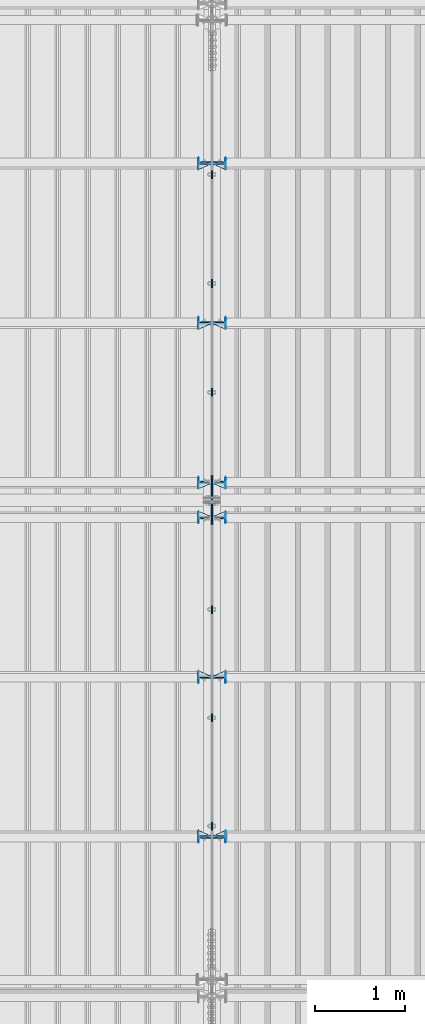
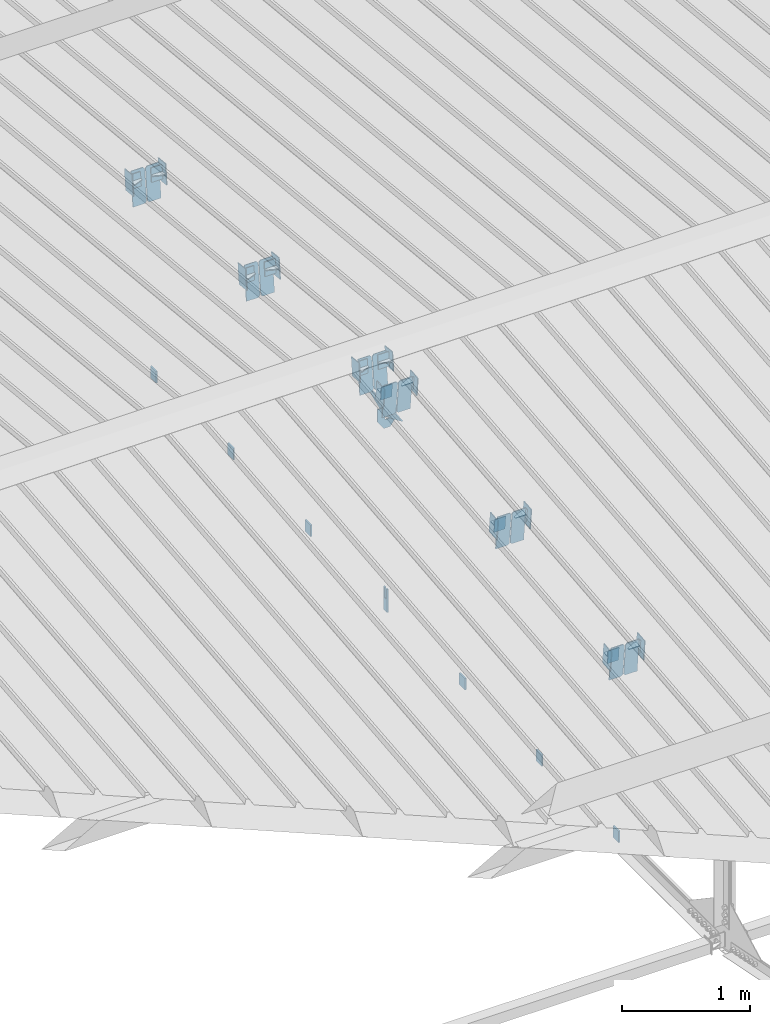
# One storey, part 129 of 709: 58 plates, 21 elements without a shape of their own.
"""IFC4 building model written with IfcOpenShell, lengths in millimetres."""

from ifc_helpers import new_model, si_unit, direction, frame, origin_with_axes, place, context, subcontext, project, spatial, line, indexed_curve, outline, extrude, material, element, aggregate, save


model = new_model("IFC4")

# Units and contexts
model_context = context("Model", 3, precision=0.2, world=origin_with_axes(), true_north=direction((0.0, 1.0)))
body_context = subcontext(model_context, "Body", "Model", "MODEL_VIEW")
ifc_project = project(units=[si_unit("LENGTHUNIT", "METRE", prefix="MILLI"), si_unit("AREAUNIT", "SQUARE_METRE"), si_unit("VOLUMEUNIT", "CUBIC_METRE"), si_unit("MASSUNIT", "GRAM", prefix="KILO"), si_unit("TIMEUNIT", "SECOND"), si_unit("PLANEANGLEUNIT", "RADIAN"), si_unit("SOLIDANGLEUNIT", "STERADIAN"), si_unit("THERMODYNAMICTEMPERATUREUNIT", "DEGREE_CELSIUS"), si_unit("LUMINOUSINTENSITYUNIT", "LUMEN")], contexts=[model_context])

# Site, building, storey
site_placement = place(None, origin_with_axes())
site = spatial("IfcSite", under=ifc_project, at=site_placement, CompositionType="ELEMENT")
building_placement = place(site_placement, origin_with_axes())
building = spatial("IfcBuilding", under=site, at=building_placement, Name="Undefined", CompositionType="ELEMENT")
storey_placement = place(building_placement, origin_with_axes())
storey = spatial("IfcBuildingStorey", under=building, at=storey_placement, Name="Undefined", CompositionType="ELEMENT", Elevation=0.0)

# Assembly, plates
assembly_1_placement = place(storey_placement, frame((28000.0, 346.0, 7089.70002), z_axis=(1.0, 0.0, 0.0), x_axis=(0.0, 0.9950371902, 0.099503719)))
assembly_1 = element("IfcElementAssembly", 1, at=assembly_1_placement, inside=storey)
ifc_material = material(Name="C355-6", Category="STEEL")
plate_1_placement = place(assembly_1_placement, frame((10515.43997, 163.0, 127.0), z_axis=(-1.0, 0.0, 0.0), x_axis=(0.0, 0.0, -1.0)))
plate_1 = element("IfcPlate", 2, at=plate_1_placement, material=ifc_material, ObjectType="589", context=body_context, shape_type="SolidModel", body=[
    extrude(outline(indexed_curve([(0.0, 0.0), (108.0, 0.0), (123.0, 15.0), (123.0, 311.0), (108.0, 326.0), (0.0, 326.0)], segments=[line(1, 2, 3, 4, 5, 6, 1)])), frame((0.0, 0.0, 4.0), z_axis=(0.0, 0.0, 1.0), x_axis=(1.0, 0.0, 0.0)), (0.0, 0.0, -1.0), 8.0),
])
plate_2_placement = place(assembly_1_placement, frame((8733.29528, 163.0, 127.0), z_axis=(-1.0, 0.0, 0.0), x_axis=(0.0, 0.0, -1.0)))
plate_2 = element("IfcPlate", 3, at=plate_2_placement, material=ifc_material, ObjectType="585", context=body_context, shape_type="SolidModel", body=[
    extrude(outline(indexed_curve([(0.0, 0.0), (108.0, 0.0), (123.0, 15.0), (123.0, 311.0), (108.0, 326.0), (0.0, 326.0)], segments=[line(1, 2, 3, 4, 5, 6, 1)])), frame((0.0, 0.0, 4.0), z_axis=(0.0, 0.0, 1.0), x_axis=(1.0, 0.0, 0.0)), (0.0, 0.0, -1.0), 8.0),
])
plate_3_placement = place(assembly_1_placement, frame((8733.29528, 163.0, -127.0), z_axis=(1.0, 0.0, 0.0), x_axis=(0.0, 0.0, 1.0)))
plate_3 = element("IfcPlate", 4, at=plate_3_placement, material=ifc_material, ObjectType="585", context=body_context, shape_type="SolidModel", body=[
    extrude(outline(indexed_curve([(0.0, 0.0), (108.0, 0.0), (123.0, 15.0), (123.0, 311.0), (108.0, 326.0), (0.0, 326.0)], segments=[line(1, 2, 3, 4, 5, 6, 1)])), frame((0.0, 0.0, 4.0), z_axis=(0.0, 0.0, 1.0), x_axis=(1.0, 0.0, 0.0)), (0.0, 0.0, -1.0), 8.0),
])
plate_4_placement = place(assembly_1_placement, frame((6951.15059, 163.0, 127.0), z_axis=(-1.0, 0.0, 0.0), x_axis=(0.0, 0.0, -1.0)))
plate_4 = element("IfcPlate", 5, at=plate_4_placement, material=ifc_material, ObjectType="585", context=body_context, shape_type="SolidModel", body=[
    extrude(outline(indexed_curve([(0.0, 0.0), (108.0, 0.0), (123.0, 15.0), (123.0, 311.0), (108.0, 326.0), (0.0, 326.0)], segments=[line(1, 2, 3, 4, 5, 6, 1)])), frame((0.0, 0.0, 4.0), z_axis=(0.0, 0.0, 1.0), x_axis=(1.0, 0.0, 0.0)), (0.0, 0.0, -1.0), 8.0),
])
plate_5_placement = place(assembly_1_placement, frame((6951.15059, 163.0, -127.0), z_axis=(1.0, 0.0, 0.0), x_axis=(0.0, 0.0, 1.0)))
plate_5 = element("IfcPlate", 6, at=plate_5_placement, material=ifc_material, ObjectType="585", context=body_context, shape_type="SolidModel", body=[
    extrude(outline(indexed_curve([(0.0, 0.0), (108.0, 0.0), (123.0, 15.0), (123.0, 311.0), (108.0, 326.0), (0.0, 326.0)], segments=[line(1, 2, 3, 4, 5, 6, 1)])), frame((0.0, 0.0, 4.0), z_axis=(0.0, 0.0, 1.0), x_axis=(1.0, 0.0, 0.0)), (0.0, 0.0, -1.0), 8.0),
])
plate_6_placement = place(assembly_1_placement, frame((10515.43997, 163.0, -127.0), z_axis=(1.0, 0.0, 0.0), x_axis=(0.0, 0.0, 1.0)))
plate_6 = element("IfcPlate", 7, at=plate_6_placement, material=ifc_material, ObjectType="589", context=body_context, shape_type="SolidModel", body=[
    extrude(outline(indexed_curve([(0.0, 0.0), (108.0, 0.0), (123.0, 15.0), (123.0, 311.0), (108.0, 326.0), (0.0, 326.0)], segments=[line(1, 2, 3, 4, 5, 6, 1)])), frame((0.0, 0.0, 4.0), z_axis=(0.0, 0.0, 1.0), x_axis=(1.0, 0.0, 0.0)), (0.0, 0.0, -1.0), 8.0),
])
plate_7_placement = place(assembly_1_placement, frame((10651.77731, -302.35483, 0.0), z_axis=(0.0, 0.0, 1.0), x_axis=(0.099503719, 0.9950371902, 0.0)))
plate_7 = element("IfcPlate", 8, at=plate_7_placement, material=ifc_material, ObjectType="439", context=body_context, shape_type="SolidModel", body=[
    extrude(outline(indexed_curve([(0.0, 0.0), (130.0, 0.0), (105.12407, 248.7593)], segments=[line(1, 2, 3, 1)])), frame((0.0, 0.0, 6.0), z_axis=(0.0, 0.0, 1.0), x_axis=(1.0, 0.0, 0.0)), (0.0, 0.0, -1.0), 12.0),
])
aggregate(assembly_1, [plate_1, plate_2, plate_3, plate_4, plate_5, plate_6, plate_7])

assembly_2_placement = place(storey_placement, frame((28000.0, 21654.0, 7089.70002), z_axis=(-1.0, 0.0, 0.0), x_axis=(0.0, -0.9950371902, 0.099503719)))
assembly_2 = element("IfcElementAssembly", 9, at=assembly_2_placement, inside=storey)
plate_8_placement = place(assembly_2_placement, frame((6951.15059, 163.0, -127.0), z_axis=(1.0, 0.0, 0.0), x_axis=(0.0, 0.0, 1.0)))
plate_8 = element("IfcPlate", 10, at=plate_8_placement, material=ifc_material, ObjectType="585", context=body_context, shape_type="SolidModel", body=[
    extrude(outline(indexed_curve([(0.0, 0.0), (108.0, 0.0), (123.0, 15.0), (123.0, 311.0), (108.0, 326.0), (0.0, 326.0)], segments=[line(1, 2, 3, 4, 5, 6, 1)])), frame((0.0, 0.0, 4.0), z_axis=(0.0, 0.0, 1.0), x_axis=(1.0, 0.0, 0.0)), (0.0, 0.0, -1.0), 8.0),
])
plate_9_placement = place(assembly_2_placement, frame((8733.29528, 163.0, -127.0), z_axis=(1.0, 0.0, 0.0), x_axis=(0.0, 0.0, 1.0)))
plate_9 = element("IfcPlate", 11, at=plate_9_placement, material=ifc_material, ObjectType="585", context=body_context, shape_type="SolidModel", body=[
    extrude(outline(indexed_curve([(0.0, 0.0), (108.0, 0.0), (123.0, 15.0), (123.0, 311.0), (108.0, 326.0), (0.0, 326.0)], segments=[line(1, 2, 3, 4, 5, 6, 1)])), frame((0.0, 0.0, 4.0), z_axis=(0.0, 0.0, 1.0), x_axis=(1.0, 0.0, 0.0)), (0.0, 0.0, -1.0), 8.0),
])
plate_10_placement = place(assembly_2_placement, frame((8733.29528, 163.0, 127.0), z_axis=(-1.0, 0.0, 0.0), x_axis=(0.0, 0.0, -1.0)))
plate_10 = element("IfcPlate", 12, at=plate_10_placement, material=ifc_material, ObjectType="585", context=body_context, shape_type="SolidModel", body=[
    extrude(outline(indexed_curve([(0.0, 0.0), (108.0, 0.0), (123.0, 15.0), (123.0, 311.0), (108.0, 326.0), (0.0, 326.0)], segments=[line(1, 2, 3, 4, 5, 6, 1)])), frame((0.0, 0.0, 4.0), z_axis=(0.0, 0.0, 1.0), x_axis=(1.0, 0.0, 0.0)), (0.0, 0.0, -1.0), 8.0),
])
plate_11_placement = place(assembly_2_placement, frame((10515.43997, 163.0, -127.0), z_axis=(1.0, 0.0, 0.0), x_axis=(0.0, 0.0, 1.0)))
plate_11 = element("IfcPlate", 13, at=plate_11_placement, material=ifc_material, ObjectType="589", context=body_context, shape_type="SolidModel", body=[
    extrude(outline(indexed_curve([(0.0, 0.0), (108.0, 0.0), (123.0, 15.0), (123.0, 311.0), (108.0, 326.0), (0.0, 326.0)], segments=[line(1, 2, 3, 4, 5, 6, 1)])), frame((0.0, 0.0, 4.0), z_axis=(0.0, 0.0, 1.0), x_axis=(1.0, 0.0, 0.0)), (0.0, 0.0, -1.0), 8.0),
])
plate_12_placement = place(assembly_2_placement, frame((10515.43997, 163.0, 127.0), z_axis=(-1.0, 0.0, 0.0), x_axis=(0.0, 0.0, -1.0)))
plate_12 = element("IfcPlate", 14, at=plate_12_placement, material=ifc_material, ObjectType="589", context=body_context, shape_type="SolidModel", body=[
    extrude(outline(indexed_curve([(0.0, 0.0), (108.0, 0.0), (123.0, 15.0), (123.0, 311.0), (108.0, 326.0), (0.0, 326.0)], segments=[line(1, 2, 3, 4, 5, 6, 1)])), frame((0.0, 0.0, 4.0), z_axis=(0.0, 0.0, 1.0), x_axis=(1.0, 0.0, 0.0)), (0.0, 0.0, -1.0), 8.0),
])
plate_13_placement = place(assembly_2_placement, frame((6951.15059, 163.0, 127.0), z_axis=(-1.0, 0.0, 0.0), x_axis=(0.0, 0.0, -1.0)))
plate_13 = element("IfcPlate", 15, at=plate_13_placement, material=ifc_material, ObjectType="585", context=body_context, shape_type="SolidModel", body=[
    extrude(outline(indexed_curve([(0.0, 0.0), (108.0, 0.0), (123.0, 15.0), (123.0, 311.0), (108.0, 326.0), (0.0, 326.0)], segments=[line(1, 2, 3, 4, 5, 6, 1)])), frame((0.0, 0.0, 4.0), z_axis=(0.0, 0.0, 1.0), x_axis=(1.0, 0.0, 0.0)), (0.0, 0.0, -1.0), 8.0),
])
plate_14_placement = place(assembly_2_placement, frame((10651.77731, -302.35483, 0.0), z_axis=(0.0, 0.0, 1.0), x_axis=(0.099503719, 0.9950371902, 0.0)))
plate_14 = element("IfcPlate", 16, at=plate_14_placement, material=ifc_material, ObjectType="439", context=body_context, shape_type="SolidModel", body=[
    extrude(outline(indexed_curve([(0.0, 0.0), (130.0, 0.0), (105.12407, 248.7593)], segments=[line(1, 2, 3, 1)])), frame((0.0, 0.0, 6.0), z_axis=(0.0, 0.0, 1.0), x_axis=(1.0, 0.0, 0.0)), (0.0, 0.0, -1.0), 12.0),
])
aggregate(assembly_2, [plate_8, plate_9, plate_10, plate_11, plate_12, plate_13, plate_14])

assembly_3_placement = place(storey_placement, frame((28000.0, 10985.0, 8155.10002), z_axis=(0.0, -1.0, 0.0), x_axis=(0.0, 0.0, -1.0)))
assembly_3 = element("IfcElementAssembly", 17, at=assembly_3_placement, inside=storey)
plate_15_placement = place(assembly_3_placement, frame((206.36285, -87.0, 14.0), z_axis=(0.0, 0.0, -1.0), x_axis=(0.0, 1.0, 0.0)))
plate_15 = element("IfcPlate", 18, at=plate_15_placement, material=ifc_material, ObjectType="440", context=body_context, shape_type="SolidModel", body=[
    extrude(outline(indexed_curve([(0.0, 0.0), (71.0, 0.0), (71.0, 120.0), (103.0, 120.0), (103.0, 0.0), (174.0, 0.0), (174.0, 120.0), (117.0, 200.0), (57.0, 200.0), (0.0, 120.0)], segments=[line(1, 2, 3, 4, 5, 6, 7, 8, 9, 10, 1)])), frame((0.0, 0.0, 4.0), z_axis=(0.0, 0.0, 1.0), x_axis=(1.0, 0.0, 0.0)), (0.0, 0.0, -1.0), 8.0),
])
plate_16_placement = place(assembly_3_placement, frame((2165.1, 0.0, 30.0), z_axis=(0.0, 1.0, 0.0), x_axis=(0.0, 0.0, -1.0)))
plate_16 = element("IfcPlate", 19, at=plate_16_placement, material=ifc_material, ObjectType="441", context=body_context, shape_type="SolidModel", body=[
    extrude(outline(indexed_curve([(0.0, 0.0), (60.0, 0.0), (60.0, 220.0), (41.0, 220.0), (41.0, 120.0), (19.0, 120.0), (19.0, 220.0), (0.0, 220.0)], segments=[line(1, 2, 3, 4, 5, 6, 7, 8, 1)])), frame((0.0, 0.0, 6.0), z_axis=(0.0, 0.0, 1.0), x_axis=(1.0, 0.0, 0.0)), (0.0, 0.0, -1.0), 12.0),
])
aggregate(assembly_3, [plate_15, plate_16])

# Assembly, plate
assembly_4_placement = place(storey_placement, frame((28000.0, 7334.75, 6100.00002), z_axis=(-1.0, 0.0, 0.0), x_axis=(0.0, 1.0, 0.0)))
assembly_4 = element("IfcElementAssembly", 20, at=assembly_4_placement, inside=storey)
plate_17_placement = place(assembly_4_placement, origin_with_axes())
plate_17 = element("IfcPlate", 21, at=plate_17_placement, material=ifc_material, ObjectType="491", context=body_context, shape_type="SolidModel", body=[
    extrude(outline(indexed_curve([(0.0, 0.0), (90.0, 0.0), (90.0, 110.0), (0.0, 110.0)], segments=[line(1, 2, 3, 4, 1)])), frame((0.0, 0.0, 6.0), z_axis=(0.0, 0.0, 1.0), x_axis=(1.0, 0.0, 0.0)), (0.0, 0.0, -1.0), 12.0),
])
aggregate(assembly_4, [plate_17])

assembly_5_placement = place(storey_placement, frame((28000.0, 8536.5, 6100.00002), z_axis=(-1.0, 0.0, 0.0), x_axis=(0.0, 1.0, 0.0)))
assembly_5 = element("IfcElementAssembly", 22, at=assembly_5_placement, inside=storey)
plate_18_placement = place(assembly_5_placement, origin_with_axes())
plate_18 = element("IfcPlate", 23, at=plate_18_placement, material=ifc_material, ObjectType="491", context=body_context, shape_type="SolidModel", body=[
    extrude(outline(indexed_curve([(0.0, 0.0), (90.0, 0.0), (90.0, 110.0), (0.0, 110.0)], segments=[line(1, 2, 3, 4, 1)])), frame((0.0, 0.0, 6.0), z_axis=(0.0, 0.0, 1.0), x_axis=(1.0, 0.0, 0.0)), (0.0, 0.0, -1.0), 12.0),
])
aggregate(assembly_5, [plate_18])

assembly_6_placement = place(storey_placement, frame((28000.0, 9738.25, 6100.00002), z_axis=(-1.0, 0.0, 0.0), x_axis=(0.0, 1.0, 0.0)))
assembly_6 = element("IfcElementAssembly", 24, at=assembly_6_placement, inside=storey)
plate_19_placement = place(assembly_6_placement, origin_with_axes())
plate_19 = element("IfcPlate", 25, at=plate_19_placement, material=ifc_material, ObjectType="491", context=body_context, shape_type="SolidModel", body=[
    extrude(outline(indexed_curve([(0.0, 0.0), (90.0, 0.0), (90.0, 110.0), (0.0, 110.0)], segments=[line(1, 2, 3, 4, 1)])), frame((0.0, 0.0, 6.0), z_axis=(0.0, 0.0, 1.0), x_axis=(1.0, 0.0, 0.0)), (0.0, 0.0, -1.0), 12.0),
])
aggregate(assembly_6, [plate_19])

assembly_7_placement = place(storey_placement, frame((28000.0, 12149.25, 6100.00002), z_axis=(-1.0, 0.0, 0.0), x_axis=(0.0, 1.0, 0.0)))
assembly_7 = element("IfcElementAssembly", 26, at=assembly_7_placement, inside=storey)
plate_20_placement = place(assembly_7_placement, origin_with_axes())
plate_20 = element("IfcPlate", 27, at=plate_20_placement, material=ifc_material, ObjectType="491", context=body_context, shape_type="SolidModel", body=[
    extrude(outline(indexed_curve([(0.0, 0.0), (90.0, 0.0), (90.0, 110.0), (0.0, 110.0)], segments=[line(1, 2, 3, 4, 1)])), frame((0.0, 0.0, 6.0), z_axis=(0.0, 0.0, 1.0), x_axis=(1.0, 0.0, 0.0)), (0.0, 0.0, -1.0), 12.0),
])
aggregate(assembly_7, [plate_20])

assembly_8_placement = place(storey_placement, frame((28000.0, 13358.5, 6100.00002), z_axis=(-1.0, 0.0, 0.0), x_axis=(0.0, 1.0, 0.0)))
assembly_8 = element("IfcElementAssembly", 28, at=assembly_8_placement, inside=storey)
plate_21_placement = place(assembly_8_placement, origin_with_axes())
plate_21 = element("IfcPlate", 29, at=plate_21_placement, material=ifc_material, ObjectType="491", context=body_context, shape_type="SolidModel", body=[
    extrude(outline(indexed_curve([(0.0, 0.0), (90.0, 0.0), (90.0, 110.0), (0.0, 110.0)], segments=[line(1, 2, 3, 4, 1)])), frame((0.0, 0.0, 6.0), z_axis=(0.0, 0.0, 1.0), x_axis=(1.0, 0.0, 0.0)), (0.0, 0.0, -1.0), 12.0),
])
aggregate(assembly_8, [plate_21])

assembly_9_placement = place(storey_placement, frame((28000.0, 14567.75, 6100.00002), z_axis=(-1.0, 0.0, 0.0), x_axis=(0.0, 1.0, 0.0)))
assembly_9 = element("IfcElementAssembly", 30, at=assembly_9_placement, inside=storey)
plate_22_placement = place(assembly_9_placement, origin_with_axes())
plate_22 = element("IfcPlate", 31, at=plate_22_placement, material=ifc_material, ObjectType="491", context=body_context, shape_type="SolidModel", body=[
    extrude(outline(indexed_curve([(0.0, 0.0), (90.0, 0.0), (90.0, 110.0), (0.0, 110.0)], segments=[line(1, 2, 3, 4, 1)])), frame((0.0, 0.0, 6.0), z_axis=(0.0, 0.0, 1.0), x_axis=(1.0, 0.0, 0.0)), (0.0, 0.0, -1.0), 12.0),
])
aggregate(assembly_9, [plate_22])

# Assembly, plates
assembly_10_placement = place(storey_placement, frame((22000.0, 7263.34988, 7854.7991), z_axis=(0.0, 0.9950371902, 0.099503719), x_axis=(1.0, 0.0, 0.0)))
assembly_10 = element("IfcElementAssembly", 32, at=assembly_10_placement, inside=storey)
plate_23_placement = place(assembly_10_placement, frame((5953.0, 0.0, 60.0), z_axis=(0.0, -1.0, 0.0), x_axis=(-1.0, 0.0, 0.0)))
plate_23 = element("IfcPlate", 33, at=plate_23_placement, material=ifc_material, ObjectType="588", context=body_context, shape_type="SolidModel", body=[
    extrude(outline(indexed_curve([(0.0, 36.0), (80.0, 0.0), (100.0, 0.0), (100.0, 56.0), (0.0, 56.0)], segments=[line(1, 2, 3, 4, 5, 1)])), frame((0.0, 0.0, 4.0), z_axis=(0.0, 0.0, 1.0), x_axis=(1.0, 0.0, 0.0)), (0.0, 0.0, -1.0), 8.0),
])
plate_24_placement = place(assembly_10_placement, frame((5953.0, 65.0, 0.0), z_axis=(0.0, 0.0, 1.0), x_axis=(-1.0, 0.0, 0.0)))
plate_24 = element("IfcPlate", 34, at=plate_24_placement, material=ifc_material, ObjectType="587", context=body_context, shape_type="SolidModel", body=[
    extrude(outline(indexed_curve([(0.0, 0.0), (100.0, 0.0), (100.0, 130.0), (0.0, 130.0)], segments=[line(1, 2, 3, 4, 1)])), frame((0.0, 0.0, 4.0), z_axis=(0.0, 0.0, 1.0), x_axis=(1.0, 0.0, 0.0)), (0.0, 0.0, -1.0), 8.0),
])
plate_25_placement = place(assembly_10_placement, frame((5849.0, -98.0, 60.0), z_axis=(1.0, 0.0, 0.0), x_axis=(0.0, 0.0, -1.0)))
plate_25 = element("IfcPlate", 35, at=plate_25_placement, material=ifc_material, ObjectType="586", context=body_context, shape_type="SolidModel", body=[
    extrude(outline(indexed_curve([(0.0, 0.0), (120.0, 0.0), (120.0, 196.0), (0.0, 196.0)], segments=[line(1, 2, 3, 4, 1)])), frame((0.0, 0.0, 4.0), z_axis=(0.0, 0.0, 1.0), x_axis=(1.0, 0.0, 0.0)), (0.0, 0.0, -1.0), 8.0),
])
aggregate(assembly_10, [plate_23, plate_24, plate_25])

assembly_11_placement = place(storey_placement, frame((22000.0, 9036.65012, 8032.12913), z_axis=(0.0, 0.9950371902, 0.099503719), x_axis=(1.0, 0.0, 0.0)))
assembly_11 = element("IfcElementAssembly", 36, at=assembly_11_placement, inside=storey)
plate_26_placement = place(assembly_11_placement, frame((5849.0, -98.0, 60.0), z_axis=(1.0, 0.0, 0.0), x_axis=(0.0, 0.0, -1.0)))
plate_26 = element("IfcPlate", 37, at=plate_26_placement, material=ifc_material, ObjectType="586", context=body_context, shape_type="SolidModel", body=[
    extrude(outline(indexed_curve([(0.0, 0.0), (120.0, 0.0), (120.0, 196.0), (0.0, 196.0)], segments=[line(1, 2, 3, 4, 1)])), frame((0.0, 0.0, 4.0), z_axis=(0.0, 0.0, 1.0), x_axis=(1.0, 0.0, 0.0)), (0.0, 0.0, -1.0), 8.0),
])
plate_27_placement = place(assembly_11_placement, frame((5953.0, 0.0, 60.0), z_axis=(0.0, -1.0, 0.0), x_axis=(-1.0, 0.0, 0.0)))
plate_27 = element("IfcPlate", 38, at=plate_27_placement, material=ifc_material, ObjectType="588", context=body_context, shape_type="SolidModel", body=[
    extrude(outline(indexed_curve([(0.0, 36.0), (80.0, 0.0), (100.0, 0.0), (100.0, 56.0), (0.0, 56.0)], segments=[line(1, 2, 3, 4, 5, 1)])), frame((0.0, 0.0, 4.0), z_axis=(0.0, 0.0, 1.0), x_axis=(1.0, 0.0, 0.0)), (0.0, 0.0, -1.0), 8.0),
])
plate_28_placement = place(assembly_11_placement, frame((5953.0, 65.0, 0.0), z_axis=(0.0, 0.0, 1.0), x_axis=(-1.0, 0.0, 0.0)))
plate_28 = element("IfcPlate", 39, at=plate_28_placement, material=ifc_material, ObjectType="587", context=body_context, shape_type="SolidModel", body=[
    extrude(outline(indexed_curve([(0.0, 0.0), (100.0, 0.0), (100.0, 130.0), (0.0, 130.0)], segments=[line(1, 2, 3, 4, 1)])), frame((0.0, 0.0, 4.0), z_axis=(0.0, 0.0, 1.0), x_axis=(1.0, 0.0, 0.0)), (0.0, 0.0, -1.0), 8.0),
])
aggregate(assembly_11, [plate_26, plate_27, plate_28])

assembly_12_placement = place(storey_placement, frame((22000.0, 10808.95533, 8219.40952), z_axis=(0.0, 0.9950371902, 0.099503719), x_axis=(1.0, 0.0, 0.0)))
assembly_12 = element("IfcElementAssembly", 40, at=assembly_12_placement, inside=storey)
plate_29_placement = place(assembly_12_placement, frame((5953.0, 0.0, 60.0), z_axis=(0.0, -1.0, 0.0), x_axis=(-1.0, 0.0, 0.0)))
plate_29 = element("IfcPlate", 41, at=plate_29_placement, material=ifc_material, ObjectType="588", context=body_context, shape_type="SolidModel", body=[
    extrude(outline(indexed_curve([(0.0, 36.0), (80.0, 0.0), (100.0, 0.0), (100.0, 56.0), (0.0, 56.0)], segments=[line(1, 2, 3, 4, 5, 1)])), frame((0.0, 0.0, 4.0), z_axis=(0.0, 0.0, 1.0), x_axis=(1.0, 0.0, 0.0)), (0.0, 0.0, -1.0), 8.0),
])
plate_30_placement = place(assembly_12_placement, frame((5953.0, 65.0, 0.0), z_axis=(0.0, 0.0, 1.0), x_axis=(-1.0, 0.0, 0.0)))
plate_30 = element("IfcPlate", 42, at=plate_30_placement, material=ifc_material, ObjectType="587", context=body_context, shape_type="SolidModel", body=[
    extrude(outline(indexed_curve([(0.0, 0.0), (100.0, 0.0), (100.0, 130.0), (0.0, 130.0)], segments=[line(1, 2, 3, 4, 1)])), frame((0.0, 0.0, 4.0), z_axis=(0.0, 0.0, 1.0), x_axis=(1.0, 0.0, 0.0)), (0.0, 0.0, -1.0), 8.0),
])
plate_31_placement = place(assembly_12_placement, frame((5849.0, -88.0, 60.0), z_axis=(1.0, 0.0, 0.0), x_axis=(0.0, 0.0, -1.0)))
plate_31 = element("IfcPlate", 43, at=plate_31_placement, material=ifc_material, ObjectType="590", context=body_context, shape_type="SolidModel", body=[
    extrude(outline(indexed_curve([(0.0, 0.0), (120.0, 0.0), (120.0, 176.0), (0.0, 176.0)], segments=[line(1, 2, 3, 4, 1)])), frame((0.0, 0.0, 4.0), z_axis=(0.0, 0.0, 1.0), x_axis=(1.0, 0.0, 0.0)), (0.0, 0.0, -1.0), 8.0),
])
aggregate(assembly_12, [plate_29, plate_30, plate_31])

assembly_13_placement = place(storey_placement, frame((28000.0, 11191.04467, 8219.40952), z_axis=(0.0, -0.9950371902, 0.099503719), x_axis=(-1.0, 0.0, 0.0)))
assembly_13 = element("IfcElementAssembly", 44, at=assembly_13_placement, inside=storey)
plate_32_placement = place(assembly_13_placement, frame((151.0, -88.0, -60.0), z_axis=(-1.0, 0.0, 0.0), x_axis=(0.0, 0.0, 1.0)))
plate_32 = element("IfcPlate", 45, at=plate_32_placement, material=ifc_material, ObjectType="590", context=body_context, shape_type="SolidModel", body=[
    extrude(outline(indexed_curve([(0.0, 0.0), (120.0, 0.0), (120.0, 176.0), (0.0, 176.0)], segments=[line(1, 2, 3, 4, 1)])), frame((0.0, 0.0, 4.0), z_axis=(0.0, 0.0, 1.0), x_axis=(1.0, 0.0, 0.0)), (0.0, 0.0, -1.0), 8.0),
])
plate_33_placement = place(assembly_13_placement, frame((47.0, 0.0, 60.0), z_axis=(0.0, 1.0, 0.0), x_axis=(1.0, 0.0, 0.0)))
plate_33 = element("IfcPlate", 46, at=plate_33_placement, material=ifc_material, ObjectType="588", context=body_context, shape_type="SolidModel", body=[
    extrude(outline(indexed_curve([(0.0, 36.0), (80.0, 0.0), (100.0, 0.0), (100.0, 56.0), (0.0, 56.0)], segments=[line(1, 2, 3, 4, 5, 1)])), frame((0.0, 0.0, 4.0), z_axis=(0.0, 0.0, 1.0), x_axis=(1.0, 0.0, 0.0)), (0.0, 0.0, -1.0), 8.0),
])
plate_34_placement = place(assembly_13_placement, frame((47.0, -65.0, 0.0), z_axis=(0.0, 0.0, 1.0), x_axis=(1.0, 0.0, 0.0)))
plate_34 = element("IfcPlate", 47, at=plate_34_placement, material=ifc_material, ObjectType="587", context=body_context, shape_type="SolidModel", body=[
    extrude(outline(indexed_curve([(0.0, 0.0), (100.0, 0.0), (100.0, 130.0), (0.0, 130.0)], segments=[line(1, 2, 3, 4, 1)])), frame((0.0, 0.0, 4.0), z_axis=(0.0, 0.0, 1.0), x_axis=(1.0, 0.0, 0.0)), (0.0, 0.0, -1.0), 8.0),
])
aggregate(assembly_13, [plate_32, plate_33, plate_34])

assembly_14_placement = place(storey_placement, frame((28000.0, 12963.34988, 8032.12913), z_axis=(0.0, -0.9950371902, 0.099503719), x_axis=(-1.0, 0.0, 0.0)))
assembly_14 = element("IfcElementAssembly", 48, at=assembly_14_placement, inside=storey)
plate_35_placement = place(assembly_14_placement, frame((47.0, 0.0, 60.0), z_axis=(0.0, 1.0, 0.0), x_axis=(1.0, 0.0, 0.0)))
plate_35 = element("IfcPlate", 49, at=plate_35_placement, material=ifc_material, ObjectType="588", context=body_context, shape_type="SolidModel", body=[
    extrude(outline(indexed_curve([(0.0, 36.0), (80.0, 0.0), (100.0, 0.0), (100.0, 56.0), (0.0, 56.0)], segments=[line(1, 2, 3, 4, 5, 1)])), frame((0.0, 0.0, 4.0), z_axis=(0.0, 0.0, 1.0), x_axis=(1.0, 0.0, 0.0)), (0.0, 0.0, -1.0), 8.0),
])
plate_36_placement = place(assembly_14_placement, frame((47.0, -65.0, 0.0), z_axis=(0.0, 0.0, 1.0), x_axis=(1.0, 0.0, 0.0)))
plate_36 = element("IfcPlate", 50, at=plate_36_placement, material=ifc_material, ObjectType="587", context=body_context, shape_type="SolidModel", body=[
    extrude(outline(indexed_curve([(0.0, 0.0), (100.0, 0.0), (100.0, 130.0), (0.0, 130.0)], segments=[line(1, 2, 3, 4, 1)])), frame((0.0, 0.0, 4.0), z_axis=(0.0, 0.0, 1.0), x_axis=(1.0, 0.0, 0.0)), (0.0, 0.0, -1.0), 8.0),
])
plate_37_placement = place(assembly_14_placement, frame((151.0, -98.0, -60.0), z_axis=(-1.0, 0.0, 0.0), x_axis=(0.0, 0.0, 1.0)))
plate_37 = element("IfcPlate", 51, at=plate_37_placement, material=ifc_material, ObjectType="586", context=body_context, shape_type="SolidModel", body=[
    extrude(outline(indexed_curve([(0.0, 0.0), (120.0, 0.0), (120.0, 196.0), (0.0, 196.0)], segments=[line(1, 2, 3, 4, 1)])), frame((0.0, 0.0, 4.0), z_axis=(0.0, 0.0, 1.0), x_axis=(1.0, 0.0, 0.0)), (0.0, 0.0, -1.0), 8.0),
])
aggregate(assembly_14, [plate_35, plate_36, plate_37])

assembly_15_placement = place(storey_placement, frame((28000.0, 14736.65012, 7854.7991), z_axis=(0.0, -0.9950371902, 0.099503719), x_axis=(-1.0, 0.0, 0.0)))
assembly_15 = element("IfcElementAssembly", 52, at=assembly_15_placement, inside=storey)
plate_38_placement = place(assembly_15_placement, frame((151.0, -98.0, -60.0), z_axis=(-1.0, 0.0, 0.0), x_axis=(0.0, 0.0, 1.0)))
plate_38 = element("IfcPlate", 53, at=plate_38_placement, material=ifc_material, ObjectType="586", context=body_context, shape_type="SolidModel", body=[
    extrude(outline(indexed_curve([(0.0, 0.0), (120.0, 0.0), (120.0, 196.0), (0.0, 196.0)], segments=[line(1, 2, 3, 4, 1)])), frame((0.0, 0.0, 4.0), z_axis=(0.0, 0.0, 1.0), x_axis=(1.0, 0.0, 0.0)), (0.0, 0.0, -1.0), 8.0),
])
plate_39_placement = place(assembly_15_placement, frame((47.0, -65.0, 0.0), z_axis=(0.0, 0.0, 1.0), x_axis=(1.0, 0.0, 0.0)))
plate_39 = element("IfcPlate", 54, at=plate_39_placement, material=ifc_material, ObjectType="587", context=body_context, shape_type="SolidModel", body=[
    extrude(outline(indexed_curve([(0.0, 0.0), (100.0, 0.0), (100.0, 130.0), (0.0, 130.0)], segments=[line(1, 2, 3, 4, 1)])), frame((0.0, 0.0, 4.0), z_axis=(0.0, 0.0, 1.0), x_axis=(1.0, 0.0, 0.0)), (0.0, 0.0, -1.0), 8.0),
])
plate_40_placement = place(assembly_15_placement, frame((47.0, 0.0, 60.0), z_axis=(0.0, 1.0, 0.0), x_axis=(1.0, 0.0, 0.0)))
plate_40 = element("IfcPlate", 55, at=plate_40_placement, material=ifc_material, ObjectType="588", context=body_context, shape_type="SolidModel", body=[
    extrude(outline(indexed_curve([(0.0, 36.0), (80.0, 0.0), (100.0, 0.0), (100.0, 56.0), (0.0, 56.0)], segments=[line(1, 2, 3, 4, 5, 1)])), frame((0.0, 0.0, 4.0), z_axis=(0.0, 0.0, 1.0), x_axis=(1.0, 0.0, 0.0)), (0.0, 0.0, -1.0), 8.0),
])
aggregate(assembly_15, [plate_38, plate_39, plate_40])

assembly_16_placement = place(storey_placement, frame((28000.0, 7263.34988, 7854.7991), z_axis=(0.0, 0.9950371902, 0.099503719), x_axis=(1.0, 0.0, 0.0)))
assembly_16 = element("IfcElementAssembly", 56, at=assembly_16_placement, inside=storey)
plate_41_placement = place(assembly_16_placement, frame((47.0, 0.0, 60.0), z_axis=(0.0, 1.0, 0.0), x_axis=(1.0, 0.0, 0.0)))
plate_41 = element("IfcPlate", 57, at=plate_41_placement, material=ifc_material, ObjectType="588", context=body_context, shape_type="SolidModel", body=[
    extrude(outline(indexed_curve([(0.0, 36.0), (80.0, 0.0), (100.0, 0.0), (100.0, 56.0), (0.0, 56.0)], segments=[line(1, 2, 3, 4, 5, 1)])), frame((0.0, 0.0, 4.0), z_axis=(0.0, 0.0, 1.0), x_axis=(1.0, 0.0, 0.0)), (0.0, 0.0, -1.0), 8.0),
])
plate_42_placement = place(assembly_16_placement, frame((47.0, -65.0, 0.0), z_axis=(0.0, 0.0, 1.0), x_axis=(1.0, 0.0, 0.0)))
plate_42 = element("IfcPlate", 58, at=plate_42_placement, material=ifc_material, ObjectType="587", context=body_context, shape_type="SolidModel", body=[
    extrude(outline(indexed_curve([(0.0, 0.0), (100.0, 0.0), (100.0, 130.0), (0.0, 130.0)], segments=[line(1, 2, 3, 4, 1)])), frame((0.0, 0.0, 4.0), z_axis=(0.0, 0.0, 1.0), x_axis=(1.0, 0.0, 0.0)), (0.0, 0.0, -1.0), 8.0),
])
plate_43_placement = place(assembly_16_placement, frame((151.0, -98.0, -60.0), z_axis=(-1.0, 0.0, 0.0), x_axis=(0.0, 0.0, 1.0)))
plate_43 = element("IfcPlate", 59, at=plate_43_placement, material=ifc_material, ObjectType="586", context=body_context, shape_type="SolidModel", body=[
    extrude(outline(indexed_curve([(0.0, 0.0), (120.0, 0.0), (120.0, 196.0), (0.0, 196.0)], segments=[line(1, 2, 3, 4, 1)])), frame((0.0, 0.0, 4.0), z_axis=(0.0, 0.0, 1.0), x_axis=(1.0, 0.0, 0.0)), (0.0, 0.0, -1.0), 8.0),
])
aggregate(assembly_16, [plate_41, plate_42, plate_43])

assembly_17_placement = place(storey_placement, frame((28000.0, 9036.65012, 8032.12913), z_axis=(0.0, 0.9950371902, 0.099503719), x_axis=(1.0, 0.0, 0.0)))
assembly_17 = element("IfcElementAssembly", 60, at=assembly_17_placement, inside=storey)
plate_44_placement = place(assembly_17_placement, frame((47.0, 0.0, 60.0), z_axis=(0.0, 1.0, 0.0), x_axis=(1.0, 0.0, 0.0)))
plate_44 = element("IfcPlate", 61, at=plate_44_placement, material=ifc_material, ObjectType="588", context=body_context, shape_type="SolidModel", body=[
    extrude(outline(indexed_curve([(0.0, 36.0), (80.0, 0.0), (100.0, 0.0), (100.0, 56.0), (0.0, 56.0)], segments=[line(1, 2, 3, 4, 5, 1)])), frame((0.0, 0.0, 4.0), z_axis=(0.0, 0.0, 1.0), x_axis=(1.0, 0.0, 0.0)), (0.0, 0.0, -1.0), 8.0),
])
plate_45_placement = place(assembly_17_placement, frame((47.0, -65.0, 0.0), z_axis=(0.0, 0.0, 1.0), x_axis=(1.0, 0.0, 0.0)))
plate_45 = element("IfcPlate", 62, at=plate_45_placement, material=ifc_material, ObjectType="587", context=body_context, shape_type="SolidModel", body=[
    extrude(outline(indexed_curve([(0.0, 0.0), (100.0, 0.0), (100.0, 130.0), (0.0, 130.0)], segments=[line(1, 2, 3, 4, 1)])), frame((0.0, 0.0, 4.0), z_axis=(0.0, 0.0, 1.0), x_axis=(1.0, 0.0, 0.0)), (0.0, 0.0, -1.0), 8.0),
])
plate_46_placement = place(assembly_17_placement, frame((151.0, -98.0, -60.0), z_axis=(-1.0, 0.0, 0.0), x_axis=(0.0, 0.0, 1.0)))
plate_46 = element("IfcPlate", 63, at=plate_46_placement, material=ifc_material, ObjectType="586", context=body_context, shape_type="SolidModel", body=[
    extrude(outline(indexed_curve([(0.0, 0.0), (120.0, 0.0), (120.0, 196.0), (0.0, 196.0)], segments=[line(1, 2, 3, 4, 1)])), frame((0.0, 0.0, 4.0), z_axis=(0.0, 0.0, 1.0), x_axis=(1.0, 0.0, 0.0)), (0.0, 0.0, -1.0), 8.0),
])
aggregate(assembly_17, [plate_44, plate_45, plate_46])

assembly_18_placement = place(storey_placement, frame((28000.0, 10808.95533, 8219.40952), z_axis=(0.0, 0.9950371902, 0.099503719), x_axis=(1.0, 0.0, 0.0)))
assembly_18 = element("IfcElementAssembly", 64, at=assembly_18_placement, inside=storey)
plate_47_placement = place(assembly_18_placement, frame((47.0, -65.0, 0.0), z_axis=(0.0, 0.0, 1.0), x_axis=(1.0, 0.0, 0.0)))
plate_47 = element("IfcPlate", 65, at=plate_47_placement, material=ifc_material, ObjectType="587", context=body_context, shape_type="SolidModel", body=[
    extrude(outline(indexed_curve([(0.0, 0.0), (100.0, 0.0), (100.0, 130.0), (0.0, 130.0)], segments=[line(1, 2, 3, 4, 1)])), frame((0.0, 0.0, 4.0), z_axis=(0.0, 0.0, 1.0), x_axis=(1.0, 0.0, 0.0)), (0.0, 0.0, -1.0), 8.0),
])
plate_48_placement = place(assembly_18_placement, frame((151.0, -88.0, -60.0), z_axis=(-1.0, 0.0, 0.0), x_axis=(0.0, 0.0, 1.0)))
plate_48 = element("IfcPlate", 66, at=plate_48_placement, material=ifc_material, ObjectType="590", context=body_context, shape_type="SolidModel", body=[
    extrude(outline(indexed_curve([(0.0, 0.0), (120.0, 0.0), (120.0, 176.0), (0.0, 176.0)], segments=[line(1, 2, 3, 4, 1)])), frame((0.0, 0.0, 4.0), z_axis=(0.0, 0.0, 1.0), x_axis=(1.0, 0.0, 0.0)), (0.0, 0.0, -1.0), 8.0),
])
plate_49_placement = place(assembly_18_placement, frame((47.0, 0.0, 60.0), z_axis=(0.0, 1.0, 0.0), x_axis=(1.0, 0.0, 0.0)))
plate_49 = element("IfcPlate", 67, at=plate_49_placement, material=ifc_material, ObjectType="588", context=body_context, shape_type="SolidModel", body=[
    extrude(outline(indexed_curve([(0.0, 36.0), (80.0, 0.0), (100.0, 0.0), (100.0, 56.0), (0.0, 56.0)], segments=[line(1, 2, 3, 4, 5, 1)])), frame((0.0, 0.0, 4.0), z_axis=(0.0, 0.0, 1.0), x_axis=(1.0, 0.0, 0.0)), (0.0, 0.0, -1.0), 8.0),
])
aggregate(assembly_18, [plate_47, plate_48, plate_49])

assembly_19_placement = place(storey_placement, frame((34000.0, 11191.04467, 8219.40952), z_axis=(0.0, -0.9950371902, 0.099503719), x_axis=(-1.0, 0.0, 0.0)))
assembly_19 = element("IfcElementAssembly", 68, at=assembly_19_placement, inside=storey)
plate_50_placement = place(assembly_19_placement, frame((5953.0, 0.0, 60.0), z_axis=(0.0, -1.0, 0.0), x_axis=(-1.0, 0.0, 0.0)))
plate_50 = element("IfcPlate", 69, at=plate_50_placement, material=ifc_material, ObjectType="588", context=body_context, shape_type="SolidModel", body=[
    extrude(outline(indexed_curve([(0.0, 36.0), (80.0, 0.0), (100.0, 0.0), (100.0, 56.0), (0.0, 56.0)], segments=[line(1, 2, 3, 4, 5, 1)])), frame((0.0, 0.0, 4.0), z_axis=(0.0, 0.0, 1.0), x_axis=(1.0, 0.0, 0.0)), (0.0, 0.0, -1.0), 8.0),
])
plate_51_placement = place(assembly_19_placement, frame((5849.0, -88.0, 60.0), z_axis=(1.0, 0.0, 0.0), x_axis=(0.0, 0.0, -1.0)))
plate_51 = element("IfcPlate", 70, at=plate_51_placement, material=ifc_material, ObjectType="590", context=body_context, shape_type="SolidModel", body=[
    extrude(outline(indexed_curve([(0.0, 0.0), (120.0, 0.0), (120.0, 176.0), (0.0, 176.0)], segments=[line(1, 2, 3, 4, 1)])), frame((0.0, 0.0, 4.0), z_axis=(0.0, 0.0, 1.0), x_axis=(1.0, 0.0, 0.0)), (0.0, 0.0, -1.0), 8.0),
])
plate_52_placement = place(assembly_19_placement, frame((5953.0, 65.0, 0.0), z_axis=(0.0, 0.0, 1.0), x_axis=(-1.0, 0.0, 0.0)))
plate_52 = element("IfcPlate", 71, at=plate_52_placement, material=ifc_material, ObjectType="587", context=body_context, shape_type="SolidModel", body=[
    extrude(outline(indexed_curve([(0.0, 0.0), (100.0, 0.0), (100.0, 130.0), (0.0, 130.0)], segments=[line(1, 2, 3, 4, 1)])), frame((0.0, 0.0, 4.0), z_axis=(0.0, 0.0, 1.0), x_axis=(1.0, 0.0, 0.0)), (0.0, 0.0, -1.0), 8.0),
])
aggregate(assembly_19, [plate_50, plate_51, plate_52])

assembly_20_placement = place(storey_placement, frame((34000.0, 12963.34988, 8032.12913), z_axis=(0.0, -0.9950371902, 0.099503719), x_axis=(-1.0, 0.0, 0.0)))
assembly_20 = element("IfcElementAssembly", 72, at=assembly_20_placement, inside=storey)
plate_53_placement = place(assembly_20_placement, frame((5953.0, 65.0, 0.0), z_axis=(0.0, 0.0, 1.0), x_axis=(-1.0, 0.0, 0.0)))
plate_53 = element("IfcPlate", 73, at=plate_53_placement, material=ifc_material, ObjectType="587", context=body_context, shape_type="SolidModel", body=[
    extrude(outline(indexed_curve([(0.0, 0.0), (100.0, 0.0), (100.0, 130.0), (0.0, 130.0)], segments=[line(1, 2, 3, 4, 1)])), frame((0.0, 0.0, 4.0), z_axis=(0.0, 0.0, 1.0), x_axis=(1.0, 0.0, 0.0)), (0.0, 0.0, -1.0), 8.0),
])
plate_54_placement = place(assembly_20_placement, frame((5849.0, -98.0, 60.0), z_axis=(1.0, 0.0, 0.0), x_axis=(0.0, 0.0, -1.0)))
plate_54 = element("IfcPlate", 74, at=plate_54_placement, material=ifc_material, ObjectType="586", context=body_context, shape_type="SolidModel", body=[
    extrude(outline(indexed_curve([(0.0, 0.0), (120.0, 0.0), (120.0, 196.0), (0.0, 196.0)], segments=[line(1, 2, 3, 4, 1)])), frame((0.0, 0.0, 4.0), z_axis=(0.0, 0.0, 1.0), x_axis=(1.0, 0.0, 0.0)), (0.0, 0.0, -1.0), 8.0),
])
plate_55_placement = place(assembly_20_placement, frame((5953.0, 0.0, 60.0), z_axis=(0.0, -1.0, 0.0), x_axis=(-1.0, 0.0, 0.0)))
plate_55 = element("IfcPlate", 75, at=plate_55_placement, material=ifc_material, ObjectType="588", context=body_context, shape_type="SolidModel", body=[
    extrude(outline(indexed_curve([(0.0, 36.0), (80.0, 0.0), (100.0, 0.0), (100.0, 56.0), (0.0, 56.0)], segments=[line(1, 2, 3, 4, 5, 1)])), frame((0.0, 0.0, 4.0), z_axis=(0.0, 0.0, 1.0), x_axis=(1.0, 0.0, 0.0)), (0.0, 0.0, -1.0), 8.0),
])
aggregate(assembly_20, [plate_53, plate_54, plate_55])

assembly_21_placement = place(storey_placement, frame((34000.0, 14736.65012, 7854.7991), z_axis=(0.0, -0.9950371902, 0.099503719), x_axis=(-1.0, 0.0, 0.0)))
assembly_21 = element("IfcElementAssembly", 76, at=assembly_21_placement, inside=storey)
plate_56_placement = place(assembly_21_placement, frame((5953.0, 0.0, 60.0), z_axis=(0.0, -1.0, 0.0), x_axis=(-1.0, 0.0, 0.0)))
plate_56 = element("IfcPlate", 77, at=plate_56_placement, material=ifc_material, ObjectType="588", context=body_context, shape_type="SolidModel", body=[
    extrude(outline(indexed_curve([(0.0, 36.0), (80.0, 0.0), (100.0, 0.0), (100.0, 56.0), (0.0, 56.0)], segments=[line(1, 2, 3, 4, 5, 1)])), frame((0.0, 0.0, 4.0), z_axis=(0.0, 0.0, 1.0), x_axis=(1.0, 0.0, 0.0)), (0.0, 0.0, -1.0), 8.0),
])
plate_57_placement = place(assembly_21_placement, frame((5953.0, 65.0, 0.0), z_axis=(0.0, 0.0, 1.0), x_axis=(-1.0, 0.0, 0.0)))
plate_57 = element("IfcPlate", 78, at=plate_57_placement, material=ifc_material, ObjectType="587", context=body_context, shape_type="SolidModel", body=[
    extrude(outline(indexed_curve([(0.0, 0.0), (100.0, 0.0), (100.0, 130.0), (0.0, 130.0)], segments=[line(1, 2, 3, 4, 1)])), frame((0.0, 0.0, 4.0), z_axis=(0.0, 0.0, 1.0), x_axis=(1.0, 0.0, 0.0)), (0.0, 0.0, -1.0), 8.0),
])
plate_58_placement = place(assembly_21_placement, frame((5849.0, -98.0, 60.0), z_axis=(1.0, 0.0, 0.0), x_axis=(0.0, 0.0, -1.0)))
plate_58 = element("IfcPlate", 79, at=plate_58_placement, material=ifc_material, ObjectType="586", context=body_context, shape_type="SolidModel", body=[
    extrude(outline(indexed_curve([(0.0, 0.0), (120.0, 0.0), (120.0, 196.0), (0.0, 196.0)], segments=[line(1, 2, 3, 4, 1)])), frame((0.0, 0.0, 4.0), z_axis=(0.0, 0.0, 1.0), x_axis=(1.0, 0.0, 0.0)), (0.0, 0.0, -1.0), 8.0),
])
aggregate(assembly_21, [plate_56, plate_57, plate_58])

save(model, "model.ifc")
